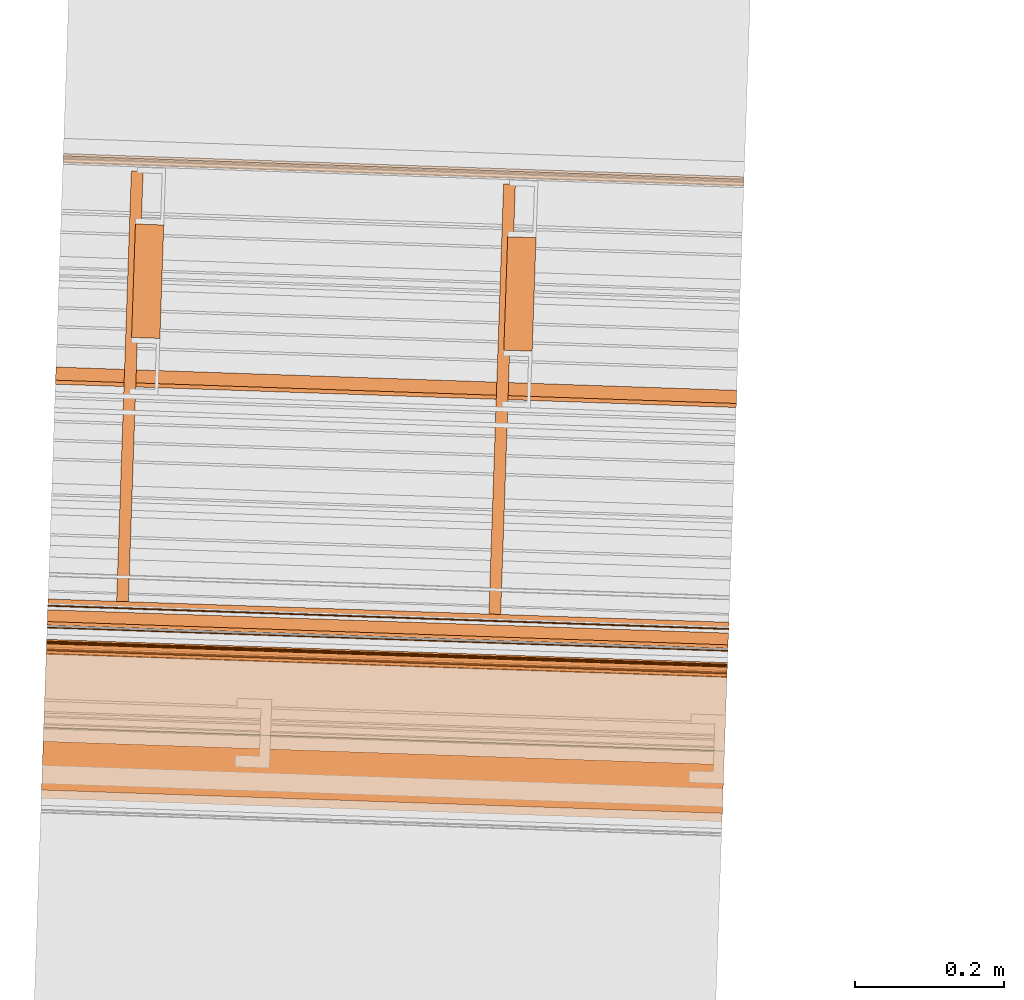
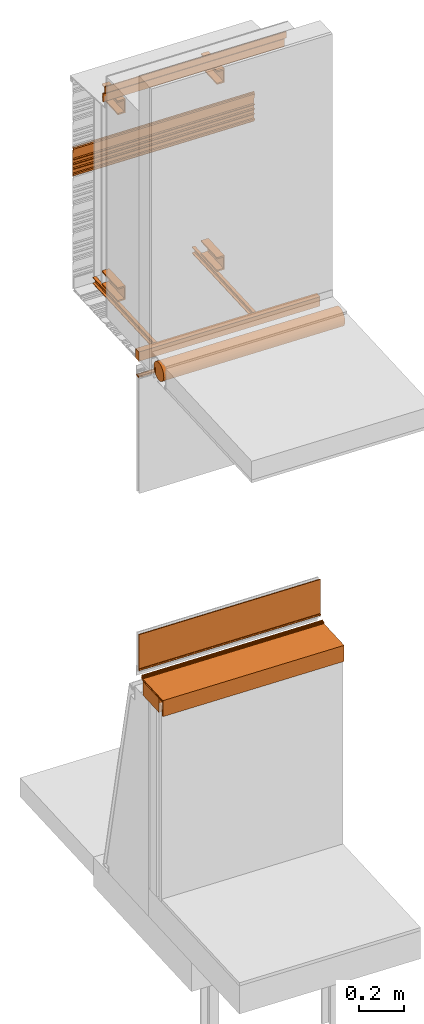
# One storey, part 9 of 36: 18 proxies.
"""IFC2X3 building model written with IfcOpenShell, lengths in feet."""

from ifc_helpers import new_model, entity, si_unit, converted_unit, derived_unit, direction, frame, frame_2d, origin, origin_2d_with_axis, place, context, subcontext, project, spatial, polyline, circle_curve, parameter, trimmed, segment, composite_curve, rectangle, outline, extrude, source, transform, mapped, material, type_object, type_shapes, element, save


model = new_model("IFC2X3")

# Units and contexts
model_context = context("Model", 3, precision=0.0001, world=origin(), true_north=direction((6.12303176911189e-17, 1.0)))
body_context = subcontext(model_context, "Body", "Model", "MODEL_VIEW")
ifc_project = project(units=[converted_unit("LENGTHUNIT", "FOOT", entity("IfcRatioMeasure", 0.3048), si_unit("LENGTHUNIT", "METRE"), dimensions=[1, 0, 0, 0, 0, 0, 0]), converted_unit("AREAUNIT", "SQUARE FOOT", entity("IfcRatioMeasure", 0.09290304), si_unit("AREAUNIT", "SQUARE_METRE"), dimensions=[2, 0, 0, 0, 0, 0, 0]), converted_unit("VOLUMEUNIT", "CUBIC FOOT", entity("IfcRatioMeasure", 0.028316846592), si_unit("VOLUMEUNIT", "CUBIC_METRE"), dimensions=[3, 0, 0, 0, 0, 0, 0]), converted_unit("PLANEANGLEUNIT", "DEGREE", entity("IfcRatioMeasure", 0.0174532925199433), si_unit("PLANEANGLEUNIT", "RADIAN"), dimensions=[0, 0, 0, 0, 0, 0, 0]), si_unit("MASSUNIT", "GRAM", prefix="KILO"), derived_unit("MASSDENSITYUNIT", [(si_unit("MASSUNIT", "GRAM", prefix="KILO"), 1), (si_unit("LENGTHUNIT", "METRE"), -3)]), si_unit("TIMEUNIT", "SECOND"), si_unit("FREQUENCYUNIT", "HERTZ"), si_unit("THERMODYNAMICTEMPERATUREUNIT", "DEGREE_CELSIUS"), derived_unit("THERMALTRANSMITTANCEUNIT", [(si_unit("MASSUNIT", "GRAM", prefix="KILO"), 1), (si_unit("THERMODYNAMICTEMPERATUREUNIT", "KELVIN"), -1), (si_unit("TIMEUNIT", "SECOND"), -3)]), derived_unit("VOLUMETRICFLOWRATEUNIT", [(si_unit("LENGTHUNIT", "METRE"), 3), (si_unit("TIMEUNIT", "SECOND"), -1)]), si_unit("ELECTRICCURRENTUNIT", "AMPERE"), si_unit("ELECTRICVOLTAGEUNIT", "VOLT"), si_unit("POWERUNIT", "WATT"), si_unit("FORCEUNIT", "NEWTON"), si_unit("ILLUMINANCEUNIT", "LUX"), si_unit("LUMINOUSFLUXUNIT", "LUMEN"), si_unit("LUMINOUSINTENSITYUNIT", "CANDELA"), derived_unit("USERDEFINED", [(si_unit("MASSUNIT", "GRAM", prefix="KILO"), -1), (si_unit("LENGTHUNIT", "METRE"), -2), (si_unit("TIMEUNIT", "SECOND"), 3), (si_unit("LUMINOUSFLUXUNIT", "LUMEN"), 1)]), derived_unit("LINEARVELOCITYUNIT", [(si_unit("LENGTHUNIT", "METRE"), 1), (si_unit("TIMEUNIT", "SECOND"), -1)]), si_unit("PRESSUREUNIT", "PASCAL"), derived_unit("USERDEFINED", [(si_unit("LENGTHUNIT", "METRE"), -2), (si_unit("MASSUNIT", "GRAM", prefix="KILO"), 1), (si_unit("TIMEUNIT", "SECOND"), -2)])], contexts=[model_context])

# Site, building, storey
site_placement = place(None, origin())
site = spatial("IfcSite", under=ifc_project, at=site_placement, CompositionType="ELEMENT")
building_placement = place(site_placement, origin())
building = spatial("IfcBuilding", under=site, at=building_placement, CompositionType="ELEMENT")
storey_placement = place(building_placement, origin())
storey = spatial("IfcBuildingStorey", under=building, at=storey_placement, Name="Level 1", CompositionType="ELEMENT", Elevation=0.0)

# Proxies
ifc_material_1 = material(Name="Metallic support for window frame")
building_element_proxy_type_1 = type_object("IfcBuildingElementProxyType", Name="Metal support for window frame001", PredefinedType="NOTDEFINED", material=ifc_material_1)
shared_shape_1 = source(origin(), body_context, "Body", "SweptSolid", [
    extrude(rectangle(XDim=3.0, YDim=0.107278015091848, at=frame_2d((7.105427357601e-15, 2.42861286636753e-16), x_axis=(1.0, 0.0))), frame((111.216846057744, -50.6154050021286, 9.70833333333333), z_axis=(0.0, 0.0, 1.0), x_axis=(-0.999414947916625, 0.034201781836759, 0.0)), (0.0, 0.0, 1.0), 0.166666666666668),
])
type_shapes(building_element_proxy_type_1, [shared_shape_1])
proxy_1_placement = place(storey_placement, origin())
element("IfcBuildingElementProxy", 1, at=proxy_1_placement, inside=storey, type_object=building_element_proxy_type_1, material=ifc_material_1, ObjectType="Metal support for window frame001", context=body_context, shape_type="MappedRepresentation", body=[
    mapped(shared_shape_1, transform((0.0, 0.0, 0.0), scale=1.0)),
])
ifc_material_2 = material(Name="LIGHT GAUGE METAL STUDS AND/OR FURRING")
building_element_proxy_type_2 = type_object("IfcBuildingElementProxyType", Name="Stud 004", PredefinedType="NOTDEFINED", material=ifc_material_2)
shared_shape_2 = source(origin(), body_context, "Body", "SweptSolid", [
    extrude(outline(polyline([(-0.0286458333333562, -0.0572916666666679), (0.0234374999999827, -0.0572916666666679), (0.0234374999999827, -0.046875), (-0.0182291666666801, -0.046875), (-0.0182291666666801, 0.046875), (0.0234374999999827, 0.046875), (0.0234374999999827, 0.0572916666666661), (-0.0286458333333562, 0.0572916666666661), (-0.0286458333333562, -0.0572916666666679)])), frame((110.044847585689, -50.5216266933335, 9.81770833333333), z_axis=(0.0342017818365511, 0.999414947916632, 0.0), x_axis=(-0.999414947916632, 0.0342017818365511, 0.0)), (0.0, 0.0, 1.0), 1.89583333333334),
])
type_shapes(building_element_proxy_type_2, [shared_shape_2])
proxy_2_placement = place(storey_placement, origin())
element("IfcBuildingElementProxy", 2, at=proxy_2_placement, inside=storey, type_object=building_element_proxy_type_2, material=ifc_material_2, Name="Stud 004:Stud 004", ObjectType="Stud 004", context=body_context, shape_type="MappedRepresentation", body=[
    mapped(shared_shape_2, transform((0.0, 0.0, 0.0), scale=1.0)),
])
building_element_proxy_type_3 = type_object("IfcBuildingElementProxyType", Name="Stud 003", PredefinedType="NOTDEFINED", material=ifc_material_2)
shared_shape_3 = source(origin(), body_context, "Body", "SweptSolid", [
    extrude(outline(polyline([(-0.0286458333333278, -0.0572916666666679), (0.023437500000025, -0.0572916666666679), (0.023437500000025, -0.046875), (-0.0182291666666514, -0.046875), (-0.0182291666666514, 0.046875), (0.023437500000025, 0.046875), (0.023437500000025, 0.0572916666666661), (-0.0286458333333278, 0.0572916666666661), (-0.0286458333333278, -0.0572916666666679)])), frame((111.684307802088, -50.5777319784982, 9.81770833333333), z_axis=(0.0342017818364056, 0.999414947916637, 0.0), x_axis=(-0.999414947916637, 0.0342017818364056, 0.0)), (0.0, 0.0, 1.0), 1.89583333333333),
])
type_shapes(building_element_proxy_type_3, [shared_shape_3])
proxy_3_placement = place(storey_placement, origin())
element("IfcBuildingElementProxy", 3, at=proxy_3_placement, inside=storey, type_object=building_element_proxy_type_3, material=ifc_material_2, Name="Stud 003:Stud 003", ObjectType="Stud 003", context=body_context, shape_type="MappedRepresentation", body=[
    mapped(shared_shape_3, transform((0.0, 0.0, 0.0), scale=1.0)),
])
ifc_material_3 = material(Name="METAL STUDS")
building_element_proxy_type_4 = type_object("IfcBuildingElementProxyType", Name="Metal stud 014", PredefinedType="NOTDEFINED", material=ifc_material_3)
shared_shape_4 = source(origin(), body_context, "Body", "SweptSolid", [
    extrude(outline(polyline([(-0.0661909448818519, -0.125), (0.0588090551181219, -0.125), (0.0588090551181219, -0.100393700787402), (-0.0514271653543063, -0.100393700787402), (-0.0514271653543063, 0.100393700787404), (0.0588090551181219, 0.100393700787404), (0.0588090551181219, 0.125000000000002), (-0.0661909448818519, 0.125000000000002), (-0.0661909448818519, -0.125)])), frame((110.146020542697, -49.3608525569486, 10.0), z_axis=(0.0342017818366075, 0.99941494791663, 0.0), x_axis=(-0.99941494791663, 0.0342017818366075, 0.0)), (0.0, 0.0, 1.0), 0.500000000000002),
])
type_shapes(building_element_proxy_type_4, [shared_shape_4])
proxy_4_placement = place(storey_placement, origin())
element("IfcBuildingElementProxy", 4, at=proxy_4_placement, inside=storey, type_object=building_element_proxy_type_4, material=ifc_material_3, Name="Metal stud 014:Metal stud 014", ObjectType="Metal stud 014", context=body_context, shape_type="MappedRepresentation", body=[
    mapped(shared_shape_4, transform((0.0, 0.0, 0.0), scale=1.0)),
])
building_element_proxy_type_5 = type_object("IfcBuildingElementProxyType", Name="Metal stud 011", PredefinedType="NOTDEFINED", material=ifc_material_3)
shared_shape_5 = source(origin(), body_context, "Body", "SweptSolid", [
    extrude(outline(polyline([(-0.0661909448818519, -0.125), (0.0588090551181219, -0.125), (0.0588090551181219, -0.1003937007874), (-0.0514271653543063, -0.1003937007874), (-0.0514271653543063, 0.1003937007874), (0.0588090551181219, 0.1003937007874), (0.0588090551181219, 0.125), (-0.0661909448818519, 0.125), (-0.0661909448818519, -0.125)])), frame((110.146020542697, -49.3608525569486, 13.3333333333333), z_axis=(0.0342017818366075, 0.99941494791663, 0.0), x_axis=(-0.99941494791663, 0.0342017818366075, 0.0)), (0.0, 0.0, 1.0), 0.500000000000002),
])
type_shapes(building_element_proxy_type_5, [shared_shape_5])
proxy_5_placement = place(storey_placement, origin())
element("IfcBuildingElementProxy", 5, at=proxy_5_placement, inside=storey, type_object=building_element_proxy_type_5, material=ifc_material_3, Name="Metal stud 011:Metal stud 011", ObjectType="Metal stud 011", context=body_context, shape_type="MappedRepresentation", body=[
    mapped(shared_shape_5, transform((0.0, 0.0, 0.0), scale=1.0)),
])
building_element_proxy_type_6 = type_object("IfcBuildingElementProxyType", Name="Metal stud 013", PredefinedType="NOTDEFINED", material=ifc_material_3)
shared_shape_6 = source(origin(), body_context, "Body", "SweptSolid", [
    extrude(outline(polyline([(-0.0661909448818803, -0.125), (0.0588090551181075, -0.125), (0.0588090551181075, -0.1003937007874), (-0.0514271653543347, -0.1003937007874), (-0.0514271653543347, 0.1003937007874), (0.0588090551181075, 0.1003937007874), (0.0588090551181075, 0.125), (-0.0661909448818803, 0.125), (-0.0661909448818803, -0.125)])), frame((111.785480759096, -49.4169578421136, 13.3333333333333), z_axis=(0.0342017818365468, 0.999414947916633, 0.0), x_axis=(-0.999414947916633, 0.0342017818365468, 0.0)), (0.0, 0.0, 1.0), 0.500000000000001),
])
type_shapes(building_element_proxy_type_6, [shared_shape_6])
proxy_6_placement = place(storey_placement, origin())
element("IfcBuildingElementProxy", 6, at=proxy_6_placement, inside=storey, type_object=building_element_proxy_type_6, material=ifc_material_3, Name="Metal stud 013:Metal stud 013", ObjectType="Metal stud 013", context=body_context, shape_type="MappedRepresentation", body=[
    mapped(shared_shape_6, transform((0.0, 0.0, 0.0), scale=1.0)),
])
building_element_proxy_type_7 = type_object("IfcBuildingElementProxyType", Name="Metal stud 012", PredefinedType="NOTDEFINED", material=ifc_material_3)
shared_shape_7 = source(origin(), body_context, "Body", "SweptSolid", [
    extrude(outline(polyline([(-0.0661909448818803, -0.125), (0.0588090551181075, -0.125), (0.0588090551181075, -0.100393700787402), (-0.0514271653543347, -0.100393700787402), (-0.0514271653543347, 0.100393700787404), (0.0588090551181075, 0.100393700787404), (0.0588090551181075, 0.125000000000002), (-0.0661909448818803, 0.125000000000002), (-0.0661909448818803, -0.125)])), frame((111.785480759096, -49.4169578421136, 10.0), z_axis=(0.0342017818365468, 0.999414947916633, 0.0), x_axis=(-0.999414947916633, 0.0342017818365468, 0.0)), (0.0, 0.0, 1.0), 0.500000000000001),
])
type_shapes(building_element_proxy_type_7, [shared_shape_7])
proxy_7_placement = place(storey_placement, origin())
element("IfcBuildingElementProxy", 7, at=proxy_7_placement, inside=storey, type_object=building_element_proxy_type_7, material=ifc_material_3, Name="Metal stud 012:Metal stud 012", ObjectType="Metal stud 012", context=body_context, shape_type="MappedRepresentation", body=[
    mapped(shared_shape_7, transform((0.0, 0.0, 0.0), scale=1.0)),
])
ifc_material_4 = material(Name="IMPERMEABLE WRB MEMBRANE")
building_element_proxy_type_8 = type_object("IfcBuildingElementProxyType", Name="Flashing 003", PredefinedType="NOTDEFINED", material=ifc_material_4)
shared_shape_8 = source(origin(), body_context, "Body", "SweptSolid", [
    extrude(outline(polyline([(-0.0371589137820219, 0.0154669259900352), (-0.135772181632417, -0.092340446754282), (-0.122552267089255, -0.104432931160668), (-0.0292661571907251, -0.00244938836848008), (0.0490662805214168, -0.00244938839462606), (0.12386481492159, 0.0793229091327383), (0.110644900349844, 0.0914153935652715), (0.0411735239015336, 0.0154669259900352), (-0.0371589137820219, 0.0154669259900352)])), frame((109.753215664138, -49.5269849138619, 13.807758480938), z_axis=(-0.999414947916634, 0.0342017818365113, 0.0), x_axis=(-0.0252364757862237, -0.73743851282518, 0.674942634667627)), (0.0, 0.0, -1.0), 3.0),
])
type_shapes(building_element_proxy_type_8, [shared_shape_8])
proxy_8_placement = place(storey_placement, origin())
element("IfcBuildingElementProxy", 8, at=proxy_8_placement, inside=storey, type_object=building_element_proxy_type_8, material=ifc_material_4, Name="Flashing 003:Flashing 003", ObjectType="Flashing 003", context=body_context, shape_type="MappedRepresentation", body=[
    mapped(shared_shape_8, transform((0.0, 0.0, 0.0), scale=1.0)),
])
ifc_material_5 = material(Name="Window frame")
building_element_proxy_type_9 = type_object("IfcBuildingElementProxyType", Name="Window frame 017", PredefinedType="NOTDEFINED", material=ifc_material_5)
shared_shape_9 = source(origin(), body_context, "Body", "SweptSolid", [
    extrude(outline(composite_curve([segment(polyline([(-0.0145833333334195, -0.0259583333333165), (0.0145833333334213, -0.0259583333333165)]), True, "CONTINUOUS"), segment(trimmed(circle_curve(frame_2d((-0.118933680555463, 0.0), x_axis=(0.0, -1.0)), 0.13601701388888), [parameter(78.9978270971977)], [parameter(101.002172902812)], True, "PARAMETER"), True, "CONTINUOUS"), segment(polyline([(0.0145833333334178, 0.0259583333333232), (-0.014583333333416, 0.0259583333333232)]), True, "CONTINUOUS"), segment(trimmed(circle_curve(frame_2d((0.118933680555465, 0.0), x_axis=(0.0, -1.0)), 0.13601701388888), [parameter(258.997827097188)], [parameter(281.002172902802)], True, "PARAMETER"), True, "CONTINUOUS")], self_intersect=False)), frame((109.717039781299, -50.5840853372173, 9.42538449904838), z_axis=(0.999414947916641, -0.0342017818362893, 0.0), x_axis=(0.0, 0.0, -1.0)), (0.0, 0.0, 1.0), 3.0),
])
type_shapes(building_element_proxy_type_9, [shared_shape_9])
proxy_9_placement = place(storey_placement, origin())
element("IfcBuildingElementProxy", 9, at=proxy_9_placement, inside=storey, type_object=building_element_proxy_type_9, material=ifc_material_5, Name="Window frame 017:Window frame 017", ObjectType="Window frame 017", context=body_context, shape_type="MappedRepresentation", body=[
    mapped(shared_shape_9, transform((0.0, 0.0, 0.0), scale=1.0)),
])
building_element_proxy_type_10 = type_object("IfcBuildingElementProxyType", Name="Window frame 014", PredefinedType="NOTDEFINED", material=ifc_material_5)
shared_shape_10 = source(origin(), body_context, "Body", "SweptSolid", [
    extrude(rectangle(XDim=3.0, YDim=0.00499999999997292, at=frame_2d((6.99440505513849e-15, 3.7921055184853e-15), x_axis=(1.0, 0.0))), frame((111.217669931724, -50.5913304676835, 9.41246783238191), z_axis=(0.0, 0.0, 1.0), x_axis=(-0.999414947916663, 0.0342017818356482, 0.0)), (0.0, 0.0, 1.0), 0.0208333333333321),
])
type_shapes(building_element_proxy_type_10, [shared_shape_10])
proxy_10_placement = place(storey_placement, origin())
element("IfcBuildingElementProxy", 10, at=proxy_10_placement, inside=storey, type_object=building_element_proxy_type_10, material=ifc_material_5, Name="Window frame 014:Window frame 014", ObjectType="Window frame 014", context=body_context, shape_type="MappedRepresentation", body=[
    mapped(shared_shape_10, transform((0.0, 0.0, 0.0), scale=1.0)),
])
ifc_material_6 = material()
building_element_proxy_type_11 = type_object("IfcBuildingElementProxyType", Name="panel 021", PredefinedType="NOTDEFINED", material=ifc_material_6)
shared_shape_11 = source(origin(), body_context, "Body", "SweptSolid", [
    extrude(outline(polyline([(-0.02201753168521, 0.14568014706847), (-0.02201753168521, -0.291819852931525), (-0.0116008650185618, -0.291819852931525), (-0.0116008650185618, -0.237132352931535), (0.00451787028329734, -0.237132352931535), (0.00451787028329734, -0.257965686264864), (0.0173047730392111, -0.257965686264864), (0.0173047730392111, -0.22671568626486), (-0.0116008650185618, -0.22671568626486), (-0.0116008650185618, -0.143382352931521), (0.0196491349814615, -0.143382352931521), (0.0196491349814615, -0.132965686264868), (-0.0116008650185618, -0.132965686264868), (-0.0116008650185618, -0.060049019598182), (0.0196491349814615, -0.060049019598182), (0.0196491349814615, -0.0496323529315319), (-0.0116008650185618, -0.0496323529315319), (-0.0116008650185618, 0.0232843137351324), (0.0196491349814615, 0.0232843137351324), (0.0196491349814615, 0.0337009804018074), (-0.0116008650185618, 0.0337009804018074), (-0.0116008650185618, 0.135263480401816), (-0.00118419835186385, 0.135263480401816), (-0.00118419835186385, 0.180710665113098), (0.018628763098251, 0.18994960080863), (0.018628763098251, 0.215994026661651), (-0.00118419835186385, 0.225232962029096), (-0.00118419835186385, 0.249846813735136), (-0.0116008650185618, 0.249846813735136), (-0.0116008650185618, 0.218596813735132), (0.0061931721533693, 0.210299318000233), (0.0061931721533693, 0.195644309470049), (-0.0116008650185618, 0.18734681373515), (-0.0116008650185618, 0.14568014706847), (-0.02201753168521, 0.14568014706847)])), frame((109.785926286855, -48.5711433305343, 12.021009163627), z_axis=(-0.999414947916598, 0.0342017818375703, 0.0), x_axis=(-0.0342017818375703, -0.999414947916598, 0.0)), (0.0, 0.0, -1.0), 2.99999999999999),
])
type_shapes(building_element_proxy_type_11, [shared_shape_11])
proxy_11_placement = place(storey_placement, origin())
element("IfcBuildingElementProxy", 11, at=proxy_11_placement, inside=storey, type_object=building_element_proxy_type_11, material=ifc_material_6, Name="panel 021:panel 021", ObjectType="panel 021", context=body_context, shape_type="MappedRepresentation", body=[
    mapped(shared_shape_11, transform((0.0, 0.0, 0.0), scale=1.0)),
])
ifc_material_7 = material(Name="_EXISTING CAST-IN-PLACE CONCRETE")
building_element_proxy_type_12 = type_object("IfcBuildingElementProxyType", Name="Shade roll001", PredefinedType="NOTDEFINED", material=ifc_material_7)
shared_shape_12 = source(origin(), body_context, "Body", "SweptSolid", [
    extrude(outline(composite_curve([segment(polyline([(-0.0551881001272234, -0.00515053666665571), (-0.0551881001272238, 0.00515053666665924)]), True, "CONTINUOUS"), segment(polyline([(-0.0551881001272238, 0.00515053666665924), (0.0602445874161044, 0.00515053666666024)]), True, "CONTINUOUS"), segment(trimmed(circle_curve(frame_2d((-0.0558209976272595, 0.108982059166666), x_axis=(0.0, 1.0)), 0.155731195), [parameter(228.184390515109)], [parameter(222.871447100879)], True, "PARAMETER"), True, "CONTINUOUS"), segment(polyline([(0.050131612838341, -0.0051505366666557), (-0.0551881001272234, -0.00515053666665571)]), True, "CONTINUOUS")], self_intersect=False)), frame((109.698545636149, -51.124504766406, 9.85644260849489), z_axis=(-0.999414947916628, 0.0342017818364592, -1.19209436350198e-07), x_axis=(1.19139694123403e-07, -4.07713123603271e-09, -1.0)), (0.0, 0.0, -1.0), 3.0),
])
type_shapes(building_element_proxy_type_12, [shared_shape_12])
proxy_12_placement = place(storey_placement, origin())
element("IfcBuildingElementProxy", 12, at=proxy_12_placement, inside=storey, type_object=building_element_proxy_type_12, material=ifc_material_7, Name="Shade roll001:Shade roll001", ObjectType="Shade roll001", context=body_context, shape_type="MappedRepresentation", body=[
    mapped(shared_shape_12, transform((0.0, 0.0, 0.0), scale=1.0)),
])
ifc_material_8 = material(Name="Clear glass")
building_element_proxy_type_13 = type_object("IfcBuildingElementProxyType", Name="Glass panel 008", PredefinedType="NOTDEFINED", material=ifc_material_8)
shared_shape_13 = source(origin(), body_context, "Body", "SweptSolid", [
    extrude(rectangle(XDim=3.0, YDim=0.0156249999999856, at=origin_2d_with_axis()), frame((111.215007180505, -50.6691390856228, 4.19540473523623), z_axis=(0.0, 0.0, 1.0), x_axis=(0.999414947916661, -0.0342017818357215, 0.0)), (0.0, 0.0, 1.0), 0.646205703051181),
])
type_shapes(building_element_proxy_type_13, [shared_shape_13])
proxy_13_placement = place(storey_placement, origin())
element("IfcBuildingElementProxy", 13, at=proxy_13_placement, inside=storey, type_object=building_element_proxy_type_13, material=ifc_material_8, Name="Glass panel 008:Glass panel 008", ObjectType="Glass panel 008", context=body_context, shape_type="MappedRepresentation", body=[
    mapped(shared_shape_13, transform((0.0, 0.0, 0.0), scale=1.0)),
])
building_element_proxy_type_14 = type_object("IfcBuildingElementProxyType", Name="Aluminium interior finish001", PredefinedType="NOTDEFINED", material=ifc_material_1)
shared_shape_14 = source(origin(), body_context, "Body", "SweptSolid", [
    extrude(outline(polyline([(0.410027024373925, 0.0875846499835955), (0.419324873209213, 0.0875846499835955), (0.419324873209213, 0.131037205757874), (-0.220855419113616, 0.131037205757874), (-0.220855419113616, -0.154891292896981), (-0.193820529677928, -0.154891292896981), (-0.193820529677928, -0.0398764757053804), (-0.203118378595239, -0.0398764757053804), (-0.203118378595239, -0.145593443979658), (-0.211557570196291, -0.145593443979658), (-0.211557570196291, 0.121739356840551), (0.410027024373925, 0.121739356840551), (0.410027024373925, 0.0875846499835955)])), frame((109.697995918159, -51.1405686685572, 3.98822462623033), z_axis=(0.999414947916619, -0.0342017818369507, 0.0), x_axis=(0.0342017818369507, 0.999414947916619, 0.0)), (0.0, 0.0, 1.0), 3.0),
])
type_shapes(building_element_proxy_type_14, [shared_shape_14])
proxy_14_placement = place(storey_placement, origin())
element("IfcBuildingElementProxy", 14, at=proxy_14_placement, inside=storey, type_object=building_element_proxy_type_14, material=ifc_material_1, Name="Aluminium interior finish001:Aluminium interior finish001", ObjectType="Aluminium interior finish001", context=body_context, shape_type="MappedRepresentation", body=[
    mapped(shared_shape_14, transform((0.0, 0.0, 0.0), scale=1.0)),
])
building_element_proxy_type_15 = type_object("IfcBuildingElementProxyType", Name="Metal profile 009", PredefinedType="NOTDEFINED", material=ifc_material_1)
shared_shape_15 = source(origin(), body_context, "Body", "SweptSolid", [
    extrude(outline(polyline([(-0.0660140870516146, 0.0632016241360462), (0.140467365704281, 0.0632016241360462), (0.140467365704281, 0.0729575182633422), (-0.074453278652666, 0.0729575182633422), (-0.074453278652666, -0.136159142399387), (-0.0660140870516146, -0.136159142399387), (-0.0660140870516146, 0.0632016241360462)])), frame((109.693306707097, -51.2775927467864, 4.02292359846894), z_axis=(0.999414947916628, -0.0342017818366734, 0.0), x_axis=(0.0342017818366734, 0.999414947916628, 0.0)), (0.0, 0.0, 1.0), 3.0),
])
type_shapes(building_element_proxy_type_15, [shared_shape_15])
proxy_15_placement = place(storey_placement, origin())
element("IfcBuildingElementProxy", 15, at=proxy_15_placement, inside=storey, type_object=building_element_proxy_type_15, material=ifc_material_1, Name="Metal profile 009:Metal profile 009", ObjectType="Metal profile 009", context=body_context, shape_type="MappedRepresentation", body=[
    mapped(shared_shape_15, transform((0.0, 0.0, 0.0), scale=1.0)),
])
ifc_material_9 = material()
building_element_proxy_type_16 = type_object("IfcBuildingElementProxyType", Name="Wood block 004", PredefinedType="NOTDEFINED", material=ifc_material_9)
shared_shape_16 = source(origin(), body_context, "Body", "SweptSolid", [
    extrude(rectangle(XDim=3.0, YDim=0.500000000000008, at=frame_2d((7.105427357601e-15, 2.4980018054066e-16), x_axis=(1.0, 0.0))), frame((111.202305324782, -51.0403017500905, 3.83333333333334), z_axis=(0.0, 0.0, 1.0), x_axis=(0.999414947916633, -0.0342017818365434, 0.0)), (0.0, 0.0, 1.0), 0.249999999999999),
])
type_shapes(building_element_proxy_type_16, [shared_shape_16])
proxy_16_placement = place(storey_placement, origin())
element("IfcBuildingElementProxy", 16, at=proxy_16_placement, inside=storey, type_object=building_element_proxy_type_16, material=ifc_material_9, Name="Wood block 004:Wood block 004", ObjectType="Wood block 004", context=body_context, shape_type="MappedRepresentation", body=[
    mapped(shared_shape_16, transform((0.0, 0.0, 0.0), scale=1.0)),
])
building_element_proxy_type_17 = type_object("IfcBuildingElementProxyType", Name="Window frame part 047", PredefinedType="NOTDEFINED", material=ifc_material_5)
shared_shape_17 = source(origin(), body_context, "Body", "SweptSolid", [
    extrude(outline(composite_curve([segment(polyline([(-0.00282945506245762, 0.00291666666654322), (-0.00282945506245762, 0.00999999999999091)]), True, "CONTINUOUS"), segment(trimmed(circle_curve(frame_2d((-0.00407945504675786, 0.00999999999999091), x_axis=(-1.0, 0.0)), 0.0012499999999968), [parameter(180.0)], [parameter(0.0)], True, "PARAMETER"), True, "CONTINUOUS"), segment(polyline([(-0.00532945505546592, 0.00999999999999091), (-0.00532945506244052, -0.0100000000002405)]), True, "CONTINUOUS"), segment(trimmed(circle_curve(frame_2d((-0.00407945504675834, -0.0100000000002405), x_axis=(-1.0, 0.0)), 0.0012499999999973), [parameter(0.0)], [parameter(180.0)], True, "PARAMETER"), True, "CONTINUOUS"), segment(polyline([(-0.00282945505546881, -0.0100000000002405), (-0.00282945506245762, -0.00291666666679014)]), True, "CONTINUOUS"), segment(polyline([(-0.00282945506245762, -0.00291666666679014), (0.00137389949790621, -0.00291666666679014)]), True, "CONTINUOUS"), segment(polyline([(0.00137389949790621, -0.00291666666679014), (0.00137389949790621, -0.0128166666663754)]), True, "CONTINUOUS"), segment(trimmed(circle_curve(frame_2d((0.00480723284250787, -0.0128166666663754), x_axis=(-1.0, 0.0)), 0.00343333333333822), [parameter(0.0)], [parameter(180.0)], True, "PARAMETER"), True, "CONTINUOUS"), segment(polyline([(0.00824056616713922, -0.0128166666663754), (0.00824056616458646, 0.0128166666668719)]), True, "CONTINUOUS"), segment(trimmed(circle_curve(frame_2d((0.00480723284250836, 0.0128166666668719), x_axis=(-1.0, 0.0)), 0.00343333333333822), [parameter(180.0)], [parameter(0.0)], True, "PARAMETER"), True, "CONTINUOUS"), segment(polyline([(0.00137389950045848, 0.0128166666668719), (0.00137389949790621, 0.00291666666654322)]), True, "CONTINUOUS"), segment(polyline([(0.00137389949790621, 0.00291666666654322), (-0.00282945506245762, 0.00291666666654322)]), True, "CONTINUOUS")], self_intersect=False)), frame((109.715335715164, -50.6338800871604, 4.21998806856943), z_axis=(-0.999414947916732, 0.0342017818336522, 0.0), x_axis=(0.0342017818336522, 0.999414947916732, 0.0)), (0.0, 0.0, -1.0), 3.00000000000001),
])
type_shapes(building_element_proxy_type_17, [shared_shape_17])
proxy_17_placement = place(storey_placement, origin())
element("IfcBuildingElementProxy", 17, at=proxy_17_placement, inside=storey, type_object=building_element_proxy_type_17, material=ifc_material_5, Name="Window frame part 047:Window frame part 047", ObjectType="Window frame part 047", context=body_context, shape_type="MappedRepresentation", body=[
    mapped(shared_shape_17, transform((0.0, 0.0, 0.0), scale=1.0)),
])
building_element_proxy_type_18 = type_object("IfcBuildingElementProxyType", Name="Window frame part 049", PredefinedType="NOTDEFINED", material=ifc_material_5)
shared_shape_18 = source(origin(), body_context, "Body", "SweptSolid", [
    extrude(outline(composite_curve([segment(polyline([(-0.0219733238038605, -0.0305199258919204), (-0.0173660596563875, -0.0305199258919204)]), True, "CONTINUOUS"), segment(polyline([(-0.0173660596563875, -0.0305199258919204), (-0.0217866091648495, -0.0175167391269781)]), True, "CONTINUOUS"), segment(polyline([(-0.0217866091648495, -0.0175167391269781), (0.0235898108172349, -0.0127256020126019)]), True, "CONTINUOUS"), segment(trimmed(circle_curve(frame_2d((0.029722387682631, -0.0120780847181822), x_axis=(-0.105002804417888, 0.99447192572962)), 0.00616666665977293), [parameter(90.0000000144016)], [parameter(27.037616548856)], True, "PARAMETER"), True, "CONTINUOUS"), segment(polyline([(0.0263579202282833, -0.00691009317968976), (0.0214909217395243, -0.00742398248837222)]), True, "CONTINUOUS"), segment(polyline([(0.0214909217395243, -0.00742398248837222), (0.0198073830061723, 0.000584362407971817)]), True, "CONTINUOUS"), segment(polyline([(0.0198073830061723, 0.000584362407971817), (0.0157647889790801, -0.00081008034440887)]), True, "CONTINUOUS"), segment(polyline([(0.0157647889790801, -0.00081008034440887), (0.0127205531888144, 0.0161171535383065)]), True, "CONTINUOUS"), segment(polyline([(0.0127205531888144, 0.0161171535383065), (0.0169652252094669, 0.0155977341560741)]), True, "CONTINUOUS"), segment(polyline([(0.0169652252094669, 0.0155977341560741), (0.0178294188804243, 0.0193174791477019)]), True, "CONTINUOUS"), segment(polyline([(0.0178294188804243, 0.0193174791477019), (0.0136743707054628, 0.0216210532946798)]), True, "CONTINUOUS"), segment(polyline([(0.0136743707054628, 0.0216210532946798), (0.00674887584940654, 0.0208898145708375)]), True, "CONTINUOUS"), segment(polyline([(0.00674887584940654, 0.0208898145708375), (0.00478757285966812, 0.031528839251129)]), True, "CONTINUOUS"), segment(trimmed(circle_curve(frame_2d((-0.00101351337560821, 0.0309163228816488), x_axis=(-0.105002804417888, 0.99447192572962)), 0.00583333333333166), [parameter(270.000000099438)], [parameter(89.9999998954607)], True, "PARAMETER"), True, "CONTINUOUS"), segment(polyline([(-0.00681459960712251, 0.0303038065334483), (-0.00307992071140542, -0.00506699459891509)]), True, "CONTINUOUS"), segment(polyline([(-0.00307992071140542, -0.00506699459891509), (-0.0330244612452512, -0.00822873366007766)]), True, "CONTINUOUS"), segment(trimmed(circle_curve(frame_2d((-0.0324119448879468, -0.0140298199044004), x_axis=(-0.105002804417888, 0.99447192572962)), 0.0058333333333397), [parameter(359.999999971177)], [parameter(89.9999998954607)], True, "PARAMETER"), True, "CONTINUOUS"), segment(polyline([(-0.0382130311197951, -0.0146423362526351), (-0.0374788361501396, -0.0215958294415187)]), True, "CONTINUOUS"), segment(polyline([(-0.0374788361501396, -0.0215958294415187), (-0.0219733238038605, -0.0305199258919204)]), True, "CONTINUOUS")], self_intersect=False)), frame((109.712492121424, -50.7169731290133, 4.13486488788058), z_axis=(0.999414947916758, -0.0342017818328747, 0.0), x_axis=(0.00359128300952654, 0.104941372308382, 0.99447192572962)), (0.0, 0.0, 1.0), 3.0),
])
type_shapes(building_element_proxy_type_18, [shared_shape_18])
proxy_18_placement = place(storey_placement, origin())
element("IfcBuildingElementProxy", 18, at=proxy_18_placement, inside=storey, type_object=building_element_proxy_type_18, material=ifc_material_5, Name="Window frame part 049:Window frame part 049", ObjectType="Window frame part 049", context=body_context, shape_type="MappedRepresentation", body=[
    mapped(shared_shape_18, transform((0.0, 0.0, 0.0), scale=1.0)),
])

save(model, "model.ifc")
